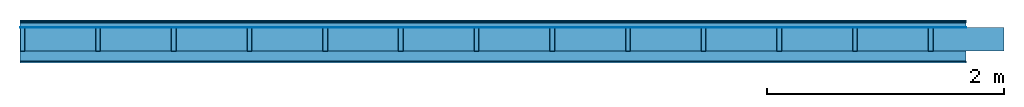
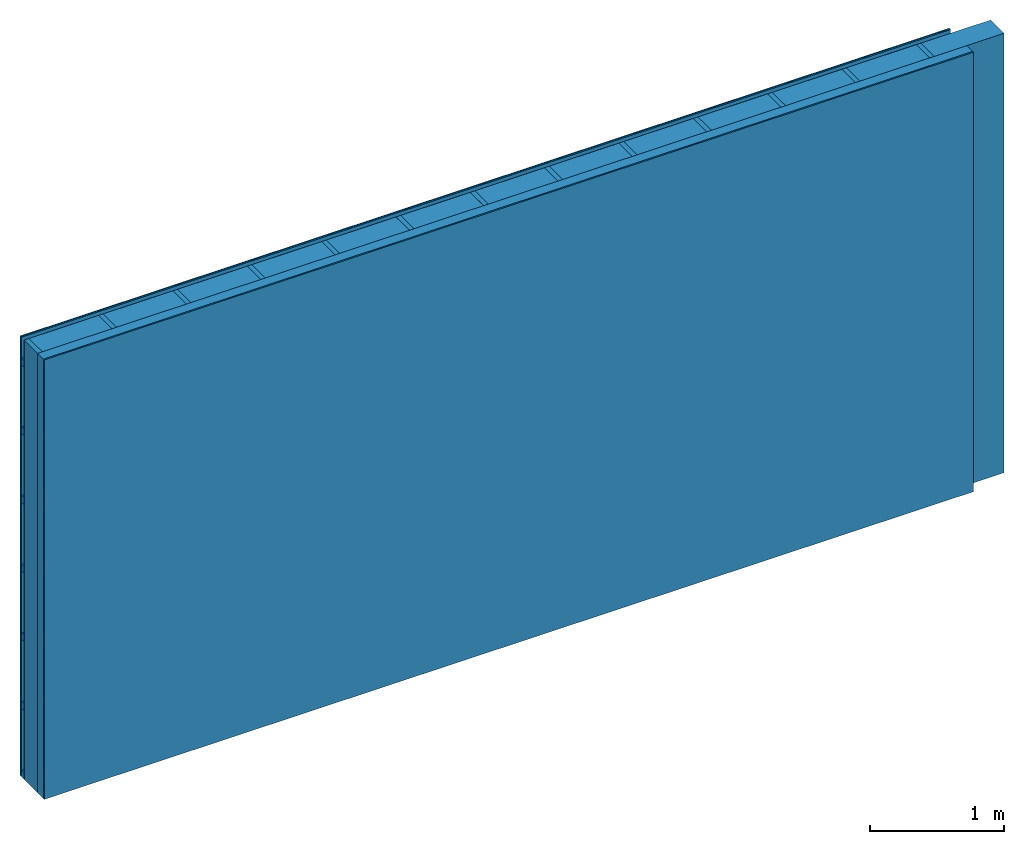
# One storey: 5 plates, 3 members, 1 element without a shape of its own.
"""IFC4 building model written with IfcOpenShell, lengths in metres."""

from ifc_helpers import new_model, si_unit, derived_unit, direction, frame, frame_2d, origin, origin_with_axes, place, context, project, spatial, rectangle, extrude, material, layer, layer_set, type_object, element, aggregate, save


model = new_model("IFC4")

# Units and contexts
plan_context = context("Plan", 3, precision=1e-05, world=origin(), true_north=direction((0.0, 1.0)))
model_context = context("Model", 3, precision=1e-05, world=origin(), true_north=direction((0.0, 1.0)))
ifc_project = project(units=[si_unit("LENGTHUNIT", "METRE"), derived_unit("SOUNDPRESSUREUNIT", [(si_unit("PRESSUREUNIT", "PASCAL", prefix="MICRO"), 0)]), si_unit("ENERGYUNIT", "JOULE", prefix="MEGA"), si_unit("MASSUNIT", "GRAM", prefix="KILO"), derived_unit("THERMALTRANSMITTANCEUNIT", [(si_unit("POWERUNIT", "WATT"), 1), (si_unit("AREAUNIT", "SQUARE_METRE"), -1), (si_unit("THERMODYNAMICTEMPERATUREUNIT", "KELVIN"), -1)]), derived_unit("AREADENSITYUNIT", [(si_unit("MASSUNIT", "GRAM", prefix="KILO"), 1), (si_unit("AREAUNIT", "SQUARE_METRE"), -1)]), derived_unit("USERDEFINED", [(si_unit("ENERGYUNIT", "JOULE", prefix="MEGA"), 1), (si_unit("AREAUNIT", "SQUARE_METRE"), -1)])], contexts=[plan_context, model_context])

# Site, building, storey
site = spatial("IfcSite", under=ifc_project)
building_placement = place(None, origin())
building = spatial("IfcBuilding", under=site, at=building_placement)
storey_placement = place(building_placement, origin())
storey = spatial("IfcBuildingStorey", under=building, at=storey_placement)

# Wall, members, plates
ifc_material_1 = material(Category="04.011")
ifc_layer_1 = layer(ifc_material_1, 0.01, Name="Surface 1")
ifc_material_2 = material(Name="mineral, cement-based building board", Category="03.003")
ifc_layer_2 = layer(ifc_material_2, 0.013, Name="Cover 1st layer")
ifc_layer_3 = layer(None, 0.04, Name="Battens / profiles (ventilation)")
ifc_material_3 = material(Name="Vapor-permeable water barrier", Category="09.006")
ifc_layer_4 = layer(ifc_material_3, 0.0005, Name="outside 1st layer")
ifc_material_4 = material(Name="of the art")
ifc_layer_5 = layer(ifc_material_4, 0.0, Name="Bond")
ifc_layer_6 = layer(None, 0.2, Name="Support")
ifc_layer_7 = layer(ifc_material_4, 0.0, Name="Bond")
ifc_material_5 = material(Name="Solid timber panel")
ifc_layer_8 = layer(ifc_material_5, 0.087, Name="1st layer")
ifc_material_6 = material(Name="Plasterboard type A", Category="03.008")
ifc_layer_9 = layer(ifc_material_6, 0.0125, Name="Covering 1st layer")
ifc_material_7 = material(Name="joints", Category="04.017")
ifc_layer_10 = layer(ifc_material_7, 0.0, Name="Surface")
ifc_layer_set = layer_set([ifc_layer_1, ifc_layer_2, ifc_layer_3, ifc_layer_4, ifc_layer_5, ifc_layer_6, ifc_layer_7, ifc_layer_8, ifc_layer_9, ifc_layer_10])
wall_type = type_object("IfcWallType", Name="D1005", PredefinedType="NOTDEFINED", material=ifc_layer_set)
wall_placement = place(None, frame((0.0, 0.0, 0.0), z_axis=(0.0, -1.0, 0.0), x_axis=(1.0, 0.0, 0.0)))
wall = element("IfcWall", 1, at=wall_placement, inside=storey, type_object=wall_type, material=ifc_layer_set, Name="Wall #1")
ifc_material_8 = material()
member_1_placement = place(wall_placement, origin())
member_1 = element("IfcMember", 2, at=member_1_placement, material=ifc_material_8, Name="Battens / profiles (ventilation)", context=plan_context, shape_type="SweptSolid", body=[
    extrude(rectangle(XDim=0.06, YDim=0.04, at=frame_2d((0.03, 0.02), x_axis=(1.0, 0.0))), frame((0.0, 0.0, 0.023), z_axis=(1.0, 0.0, 0.0), x_axis=(0.0, 1.0, 0.0)), (0.0, 0.0, 1.0), 8.0),
    extrude(rectangle(XDim=0.06, YDim=0.04, at=frame_2d((0.03, 0.02), x_axis=(1.0, 0.0))), frame((0.0, 0.625, 0.023), z_axis=(1.0, 0.0, 0.0), x_axis=(0.0, 1.0, 0.0)), (0.0, 0.0, 1.0), 8.0),
    extrude(rectangle(XDim=0.06, YDim=0.04, at=frame_2d((0.03, 0.02), x_axis=(1.0, 0.0))), frame((0.0, 1.25, 0.023), z_axis=(1.0, 0.0, 0.0), x_axis=(0.0, 1.0, 0.0)), (0.0, 0.0, 1.0), 8.0),
    extrude(rectangle(XDim=0.06, YDim=0.04, at=frame_2d((0.03, 0.02), x_axis=(1.0, 0.0))), frame((0.0, 1.875, 0.023), z_axis=(1.0, 0.0, 0.0), x_axis=(0.0, 1.0, 0.0)), (0.0, 0.0, 1.0), 8.0),
    extrude(rectangle(XDim=0.06, YDim=0.04, at=frame_2d((0.03, 0.02), x_axis=(1.0, 0.0))), frame((0.0, 2.5, 0.023), z_axis=(1.0, 0.0, 0.0), x_axis=(0.0, 1.0, 0.0)), (0.0, 0.0, 1.0), 8.0),
    extrude(rectangle(XDim=0.06, YDim=0.04, at=frame_2d((0.03, 0.02), x_axis=(1.0, 0.0))), frame((0.0, 3.125, 0.023), z_axis=(1.0, 0.0, 0.0), x_axis=(0.0, 1.0, 0.0)), (0.0, 0.0, 1.0), 8.0),
    extrude(rectangle(XDim=0.06, YDim=0.04, at=frame_2d((0.03, 0.02), x_axis=(1.0, 0.0))), frame((0.0, 3.75, 0.023), z_axis=(1.0, 0.0, 0.0), x_axis=(0.0, 1.0, 0.0)), (0.0, 0.0, 1.0), 8.0),
])
ifc_material_9 = material()
member_2_placement = place(wall_placement, origin())
member_2 = element("IfcMember", 3, at=member_2_placement, material=ifc_material_9, Name="Support", context=plan_context, shape_type="SweptSolid", body=[
    extrude(rectangle(XDim=0.04, YDim=0.2, at=frame_2d((0.02, 0.1), x_axis=(1.0, 0.0))), frame((0.0, 4.0, 0.0635), z_axis=(0.0, -1.0, 0.0), x_axis=(1.0, 0.0, 0.0)), (0.0, 0.0, 1.0), 4.0),
    extrude(rectangle(XDim=0.04, YDim=0.2, at=frame_2d((0.02, 0.1), x_axis=(1.0, 0.0))), frame((0.64, 4.0, 0.0635), z_axis=(0.0, -1.0, 0.0), x_axis=(1.0, 0.0, 0.0)), (0.0, 0.0, 1.0), 4.0),
    extrude(rectangle(XDim=0.04, YDim=0.2, at=frame_2d((0.02, 0.1), x_axis=(1.0, 0.0))), frame((1.28, 4.0, 0.0635), z_axis=(0.0, -1.0, 0.0), x_axis=(1.0, 0.0, 0.0)), (0.0, 0.0, 1.0), 4.0),
    extrude(rectangle(XDim=0.04, YDim=0.2, at=frame_2d((0.02, 0.1), x_axis=(1.0, 0.0))), frame((1.92, 4.0, 0.0635), z_axis=(0.0, -1.0, 0.0), x_axis=(1.0, 0.0, 0.0)), (0.0, 0.0, 1.0), 4.0),
    extrude(rectangle(XDim=0.04, YDim=0.2, at=frame_2d((0.02, 0.1), x_axis=(1.0, 0.0))), frame((2.56, 4.0, 0.0635), z_axis=(0.0, -1.0, 0.0), x_axis=(1.0, 0.0, 0.0)), (0.0, 0.0, 1.0), 4.0),
    extrude(rectangle(XDim=0.04, YDim=0.2, at=frame_2d((0.02, 0.1), x_axis=(1.0, 0.0))), frame((3.2, 4.0, 0.0635), z_axis=(0.0, -1.0, 0.0), x_axis=(1.0, 0.0, 0.0)), (0.0, 0.0, 1.0), 4.0),
    extrude(rectangle(XDim=0.04, YDim=0.2, at=frame_2d((0.02, 0.1), x_axis=(1.0, 0.0))), frame((3.84, 4.0, 0.0635), z_axis=(0.0, -1.0, 0.0), x_axis=(1.0, 0.0, 0.0)), (0.0, 0.0, 1.0), 4.0),
    extrude(rectangle(XDim=0.04, YDim=0.2, at=frame_2d((0.02, 0.1), x_axis=(1.0, 0.0))), frame((4.48, 4.0, 0.0635), z_axis=(0.0, -1.0, 0.0), x_axis=(1.0, 0.0, 0.0)), (0.0, 0.0, 1.0), 4.0),
    extrude(rectangle(XDim=0.04, YDim=0.2, at=frame_2d((0.02, 0.1), x_axis=(1.0, 0.0))), frame((5.12, 4.0, 0.0635), z_axis=(0.0, -1.0, 0.0), x_axis=(1.0, 0.0, 0.0)), (0.0, 0.0, 1.0), 4.0),
    extrude(rectangle(XDim=0.04, YDim=0.2, at=frame_2d((0.02, 0.1), x_axis=(1.0, 0.0))), frame((5.76, 4.0, 0.0635), z_axis=(0.0, -1.0, 0.0), x_axis=(1.0, 0.0, 0.0)), (0.0, 0.0, 1.0), 4.0),
    extrude(rectangle(XDim=0.04, YDim=0.2, at=frame_2d((0.02, 0.1), x_axis=(1.0, 0.0))), frame((6.4, 4.0, 0.0635), z_axis=(0.0, -1.0, 0.0), x_axis=(1.0, 0.0, 0.0)), (0.0, 0.0, 1.0), 4.0),
    extrude(rectangle(XDim=0.04, YDim=0.2, at=frame_2d((0.02, 0.1), x_axis=(1.0, 0.0))), frame((7.04, 4.0, 0.0635), z_axis=(0.0, -1.0, 0.0), x_axis=(1.0, 0.0, 0.0)), (0.0, 0.0, 1.0), 4.0),
    extrude(rectangle(XDim=0.04, YDim=0.2, at=frame_2d((0.02, 0.1), x_axis=(1.0, 0.0))), frame((7.68, 4.0, 0.0635), z_axis=(0.0, -1.0, 0.0), x_axis=(1.0, 0.0, 0.0)), (0.0, 0.0, 1.0), 4.0),
])
ifc_material_10 = material(Name="Mineral wool")
member_3_placement = place(wall_placement, origin())
member_3 = element("IfcMember", 4, at=member_3_placement, material=ifc_material_10, Name="Cavity", context=plan_context, shape_type="SweptSolid", body=[
    extrude(rectangle(XDim=0.6, YDim=0.2, at=frame_2d((0.3, 0.1), x_axis=(1.0, 0.0))), frame((0.04, 4.0, 0.0635), z_axis=(0.0, -1.0, 0.0), x_axis=(1.0, 0.0, 0.0)), (0.0, 0.0, 1.0), 4.0),
    extrude(rectangle(XDim=0.6, YDim=0.2, at=frame_2d((0.3, 0.1), x_axis=(1.0, 0.0))), frame((0.68, 4.0, 0.0635), z_axis=(0.0, -1.0, 0.0), x_axis=(1.0, 0.0, 0.0)), (0.0, 0.0, 1.0), 4.0),
    extrude(rectangle(XDim=0.6, YDim=0.2, at=frame_2d((0.3, 0.1), x_axis=(1.0, 0.0))), frame((1.32, 4.0, 0.0635), z_axis=(0.0, -1.0, 0.0), x_axis=(1.0, 0.0, 0.0)), (0.0, 0.0, 1.0), 4.0),
    extrude(rectangle(XDim=0.6, YDim=0.2, at=frame_2d((0.3, 0.1), x_axis=(1.0, 0.0))), frame((1.96, 4.0, 0.0635), z_axis=(0.0, -1.0, 0.0), x_axis=(1.0, 0.0, 0.0)), (0.0, 0.0, 1.0), 4.0),
    extrude(rectangle(XDim=0.6, YDim=0.2, at=frame_2d((0.3, 0.1), x_axis=(1.0, 0.0))), frame((2.6, 4.0, 0.0635), z_axis=(0.0, -1.0, 0.0), x_axis=(1.0, 0.0, 0.0)), (0.0, 0.0, 1.0), 4.0),
    extrude(rectangle(XDim=0.6, YDim=0.2, at=frame_2d((0.3, 0.1), x_axis=(1.0, 0.0))), frame((3.24, 4.0, 0.0635), z_axis=(0.0, -1.0, 0.0), x_axis=(1.0, 0.0, 0.0)), (0.0, 0.0, 1.0), 4.0),
    extrude(rectangle(XDim=0.6, YDim=0.2, at=frame_2d((0.3, 0.1), x_axis=(1.0, 0.0))), frame((3.88, 4.0, 0.0635), z_axis=(0.0, -1.0, 0.0), x_axis=(1.0, 0.0, 0.0)), (0.0, 0.0, 1.0), 4.0),
    extrude(rectangle(XDim=0.6, YDim=0.2, at=frame_2d((0.3, 0.1), x_axis=(1.0, 0.0))), frame((4.52, 4.0, 0.0635), z_axis=(0.0, -1.0, 0.0), x_axis=(1.0, 0.0, 0.0)), (0.0, 0.0, 1.0), 4.0),
    extrude(rectangle(XDim=0.6, YDim=0.2, at=frame_2d((0.3, 0.1), x_axis=(1.0, 0.0))), frame((5.16, 4.0, 0.0635), z_axis=(0.0, -1.0, 0.0), x_axis=(1.0, 0.0, 0.0)), (0.0, 0.0, 1.0), 4.0),
    extrude(rectangle(XDim=0.6, YDim=0.2, at=frame_2d((0.3, 0.1), x_axis=(1.0, 0.0))), frame((5.8, 4.0, 0.0635), z_axis=(0.0, -1.0, 0.0), x_axis=(1.0, 0.0, 0.0)), (0.0, 0.0, 1.0), 4.0),
    extrude(rectangle(XDim=0.6, YDim=0.2, at=frame_2d((0.3, 0.1), x_axis=(1.0, 0.0))), frame((6.44, 4.0, 0.0635), z_axis=(0.0, -1.0, 0.0), x_axis=(1.0, 0.0, 0.0)), (0.0, 0.0, 1.0), 4.0),
    extrude(rectangle(XDim=0.6, YDim=0.2, at=frame_2d((0.3, 0.1), x_axis=(1.0, 0.0))), frame((7.08, 4.0, 0.0635), z_axis=(0.0, -1.0, 0.0), x_axis=(1.0, 0.0, 0.0)), (0.0, 0.0, 1.0), 4.0),
    extrude(rectangle(XDim=0.6, YDim=0.2, at=frame_2d((0.3, 0.1), x_axis=(1.0, 0.0))), frame((7.72, 4.0, 0.0635), z_axis=(0.0, -1.0, 0.0), x_axis=(1.0, 0.0, 0.0)), (0.0, 0.0, 1.0), 4.0),
])
plate_1_placement = place(wall_placement, origin())
plate_1 = element("IfcPlate", 5, at=plate_1_placement, material=ifc_material_1, Name="Surface 1", context=plan_context, shape_type="SweptSolid", body=[
    extrude(rectangle(XDim=8.0, YDim=4.0, at=frame_2d((4.0, 2.0), x_axis=(1.0, 0.0))), origin_with_axes(), (0.0, 0.0, 1.0), 0.01),
])
plate_2_placement = place(wall_placement, origin())
plate_2 = element("IfcPlate", 6, at=plate_2_placement, material=ifc_material_2, Name="Cover 1st layer", context=plan_context, shape_type="SweptSolid", body=[
    extrude(rectangle(XDim=8.0, YDim=4.0, at=frame_2d((4.0, 2.0), x_axis=(1.0, 0.0))), frame((0.0, 0.0, 0.01), z_axis=(0.0, 0.0, 1.0), x_axis=(1.0, 0.0, 0.0)), (0.0, 0.0, 1.0), 0.013),
])
plate_3_placement = place(wall_placement, origin())
plate_3 = element("IfcPlate", 7, at=plate_3_placement, material=ifc_material_3, Name="outside 1st layer", context=plan_context, shape_type="SweptSolid", body=[
    extrude(rectangle(XDim=8.0, YDim=4.0, at=frame_2d((4.0, 2.0), x_axis=(1.0, 0.0))), frame((0.0, 0.0, 0.063), z_axis=(0.0, 0.0, 1.0), x_axis=(1.0, 0.0, 0.0)), (0.0, 0.0, 1.0), 0.0005),
])
plate_4_placement = place(wall_placement, origin())
plate_4 = element("IfcPlate", 8, at=plate_4_placement, material=ifc_material_5, Name="1st layer", context=plan_context, shape_type="SweptSolid", body=[
    extrude(rectangle(XDim=8.0, YDim=4.0, at=frame_2d((4.0, 2.0), x_axis=(1.0, 0.0))), frame((0.0, 0.0, 0.2635), z_axis=(0.0, 0.0, 1.0), x_axis=(1.0, 0.0, 0.0)), (0.0, 0.0, 1.0), 0.087),
])
plate_5_placement = place(wall_placement, origin())
plate_5 = element("IfcPlate", 9, at=plate_5_placement, material=ifc_material_6, Name="Covering 1st layer", context=plan_context, shape_type="SweptSolid", body=[
    extrude(rectangle(XDim=8.0, YDim=4.0, at=frame_2d((4.0, 2.0), x_axis=(1.0, 0.0))), frame((0.0, 0.0, 0.3505), z_axis=(0.0, 0.0, 1.0), x_axis=(1.0, 0.0, 0.0)), (0.0, 0.0, 1.0), 0.0125),
])
aggregate(wall, [plate_1, plate_2, member_1, plate_3, member_2, member_3, plate_4, plate_5])

save(model, "model.ifc")
